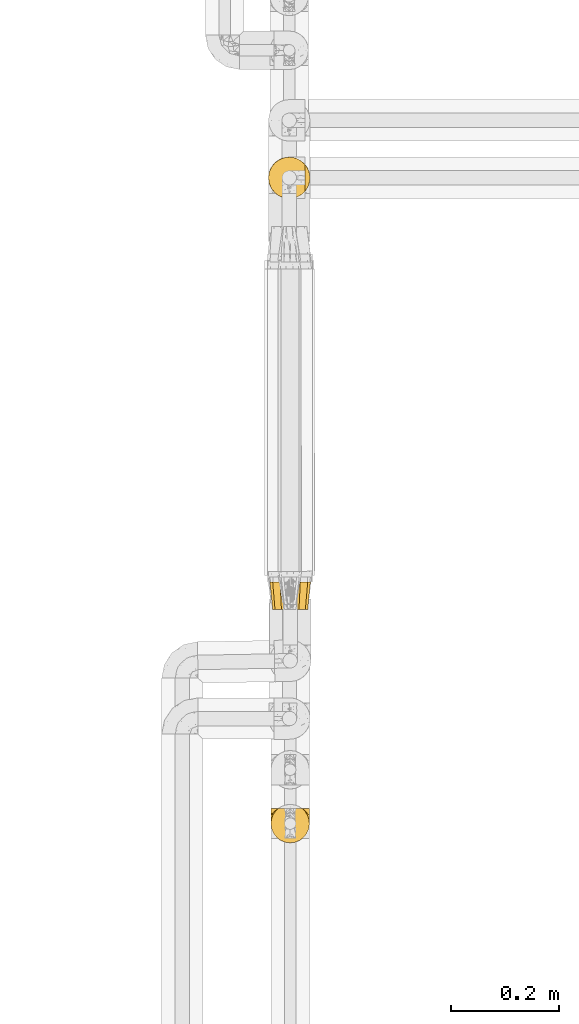
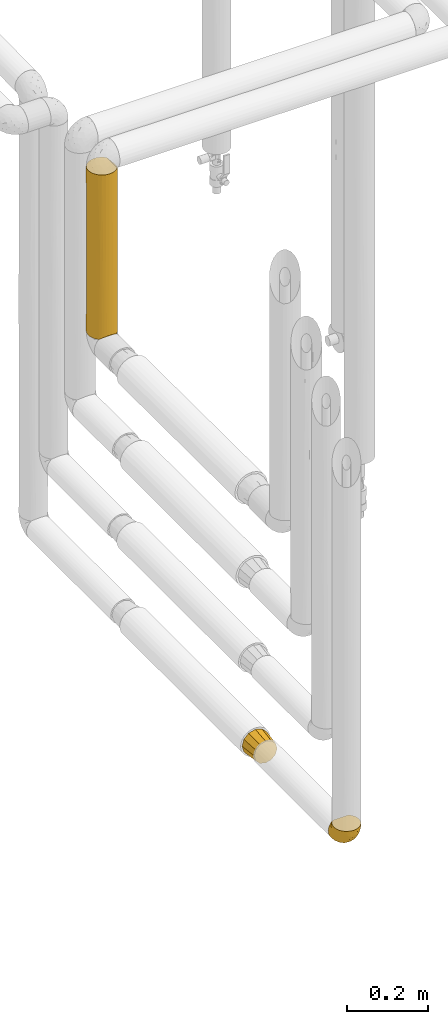
# One storey, part 75 of 827: 3 coverings.
"""IFC2X3 building model written with IfcOpenShell, lengths in millimetres."""

from ifc_helpers import new_model, entity, si_unit, converted_unit, derived_unit, direction, frame, origin, place, context, subcontext, project, spatial, faceted_brep, element, save


model = new_model("IFC2X3")

# Units and contexts
model_context = context("Model", 3, precision=0.01, world=origin(), true_north=direction((6.12303176911189e-17, 1.0)))
body_context = subcontext(model_context, "Body", "Model", "MODEL_VIEW")
ifc_project = project(units=[si_unit("LENGTHUNIT", "METRE", prefix="MILLI"), si_unit("AREAUNIT", "SQUARE_METRE"), si_unit("VOLUMEUNIT", "CUBIC_METRE"), converted_unit("PLANEANGLEUNIT", "DEGREE", entity("IfcRatioMeasure", 0.0174532925199433), si_unit("PLANEANGLEUNIT", "RADIAN"), dimensions=[0, 0, 0, 0, 0, 0, 0]), si_unit("MASSUNIT", "GRAM", prefix="KILO"), derived_unit("MASSDENSITYUNIT", [(si_unit("MASSUNIT", "GRAM", prefix="KILO"), 1), (si_unit("LENGTHUNIT", "METRE"), -3)]), derived_unit("MOMENTOFINERTIAUNIT", [(si_unit("LENGTHUNIT", "METRE"), 4)]), si_unit("TIMEUNIT", "SECOND"), si_unit("FREQUENCYUNIT", "HERTZ"), si_unit("THERMODYNAMICTEMPERATUREUNIT", "DEGREE_CELSIUS"), derived_unit("THERMALTRANSMITTANCEUNIT", [(si_unit("MASSUNIT", "GRAM", prefix="KILO"), 1), (si_unit("THERMODYNAMICTEMPERATUREUNIT", "KELVIN"), -1), (si_unit("TIMEUNIT", "SECOND"), -3)]), derived_unit("VOLUMETRICFLOWRATEUNIT", [(si_unit("LENGTHUNIT", "METRE"), 3), (si_unit("TIMEUNIT", "SECOND"), -1)]), derived_unit("MASSFLOWRATEUNIT", [(si_unit("MASSUNIT", "GRAM", prefix="KILO"), 1), (si_unit("TIMEUNIT", "SECOND"), -1)]), derived_unit("ROTATIONALFREQUENCYUNIT", [(si_unit("TIMEUNIT", "SECOND"), -1)]), si_unit("ELECTRICCURRENTUNIT", "AMPERE"), si_unit("ELECTRICVOLTAGEUNIT", "VOLT"), si_unit("POWERUNIT", "WATT"), si_unit("FORCEUNIT", "NEWTON", prefix="KILO"), si_unit("ILLUMINANCEUNIT", "LUX"), si_unit("LUMINOUSFLUXUNIT", "LUMEN"), si_unit("LUMINOUSINTENSITYUNIT", "CANDELA"), derived_unit("USERDEFINED", [(si_unit("MASSUNIT", "GRAM", prefix="KILO"), -1), (si_unit("LENGTHUNIT", "METRE"), -2), (si_unit("TIMEUNIT", "SECOND"), 3), (si_unit("LUMINOUSFLUXUNIT", "LUMEN"), 1)]), derived_unit("LINEARVELOCITYUNIT", [(si_unit("LENGTHUNIT", "METRE"), 1), (si_unit("TIMEUNIT", "SECOND"), -1)]), si_unit("PRESSUREUNIT", "PASCAL"), derived_unit("USERDEFINED", [(si_unit("LENGTHUNIT", "METRE"), -2), (si_unit("MASSUNIT", "GRAM", prefix="KILO"), 1), (si_unit("TIMEUNIT", "SECOND"), -2)]), derived_unit("LINEARFORCEUNIT", [(si_unit("MASSUNIT", "GRAM", prefix="KILO"), 1), (si_unit("LENGTHUNIT", "METRE"), 1), (si_unit("TIMEUNIT", "SECOND"), -2), (si_unit("LENGTHUNIT", "METRE"), -1)]), derived_unit("PLANARFORCEUNIT", [(si_unit("MASSUNIT", "GRAM", prefix="KILO"), 1), (si_unit("LENGTHUNIT", "METRE"), 1), (si_unit("TIMEUNIT", "SECOND"), -2), (si_unit("LENGTHUNIT", "METRE"), -2)])], contexts=[model_context])

# Site, building, storey
site_placement = place(None, origin())
site = spatial("IfcSite", under=ifc_project, at=site_placement, CompositionType="ELEMENT")
building_placement = place(site_placement, origin())
building = spatial("IfcBuilding", under=site, at=building_placement, CompositionType="ELEMENT")
storey_placement = place(building_placement, frame((0.0, 0.0, 28200.0)))
storey = spatial("IfcBuildingStorey", under=building, at=storey_placement, Name="08", CompositionType="ELEMENT", Elevation=28200.0)

# Coverings
covering_1_placement = place(storey_placement, frame((17886.73, 11719.52, 1375.75)))
element("IfcCovering", 1, at=covering_1_placement, inside=storey, Name=":ADSK_", ObjectType=":ADSK_", PredefinedType="INSULATION", context=body_context, shape_type="Brep", body=[
    faceted_brep([(63.08, 9.31, 495.15), (69.1, 14.94, 495.15), (69.1, 65.05, 495.15), (63.08, 70.68, 495.15), (56.01, 74.9, 495.15), (48.2, 77.51, 495.15), (40.0, 78.4, 495.15), (30.06, 77.09, 495.15), (20.8, 73.25, 495.15), (12.84, 67.15, 495.15), (6.74, 59.2, 495.15), (2.9, 49.93, 495.15), (1.6, 40.0, 495.15), (2.9, 30.06, 495.15), (6.74, 20.8, 495.15), (12.84, 12.84, 495.15), (20.8, 6.74, 495.15), (30.06, 2.9, 495.15), (40.0, 1.6, 495.15), (48.2, 2.48, 495.15), (56.01, 5.09, 495.15), (78.4, 40.0, 1.6), (77.51, 31.78, 1.6), (74.89, 23.96, 1.6), (70.66, 16.88, 1.6), (65.02, 10.87, 1.6), (14.91, 10.92, 1.6), (9.29, 16.93, 1.6), (5.08, 24.0, 1.6), (2.48, 31.8, 1.6), (1.6, 40.0, 1.6), (2.9, 49.93, 1.6), (6.74, 59.2, 1.6), (12.84, 67.15, 1.6), (20.8, 73.25, 1.6), (30.06, 77.09, 1.6), (40.0, 78.4, 1.6), (49.93, 77.09, 1.6), (59.2, 73.25, 1.6), (67.15, 67.15, 1.6), (73.25, 59.2, 1.6), (77.09, 49.93, 1.6), (50.17, 2.97, 245.86), (62.47, 8.86, 240.02), (59.48, 6.91, 5.56), (53.34, 3.99, 8.49), (56.56, 5.35, 187.37), (40.0, 1.6, 227.27), (46.77, 2.2, 10.28), (40.0, 1.6, 10.9), (77.02, 29.81, 250.89), (77.79, 33.21, 486.45), (76.0, 26.63, 488.25), (78.4, 40.0, 269.48), (71.11, 17.49, 256.76), (74.63, 23.41, 309.18), (78.4, 40.0, 485.85), (73.07, 20.48, 491.18), (77.02, 50.18, 254.37), (71.1, 62.51, 244.05), (74.64, 56.56, 189.86), (63.37, 70.46, 227.23), (77.79, 46.78, 486.45), (76.0, 53.36, 488.25), (73.07, 59.51, 491.18), (52.17, 76.41, 258.09), (40.0, 78.4, 278.78), (32.45, 77.65, 287.73), (25.3, 75.47, 248.37), (2.31, 47.36, 284.62), (4.52, 54.69, 248.37), (16.62, 70.46, 248.37), (9.53, 63.37, 248.37), (1.6, 40.0, 217.97), (3.57, 27.83, 238.63), (9.53, 16.62, 269.5), (29.79, 2.98, 242.35), (33.2, 2.2, 10.3), (23.4, 5.36, 306.39), (17.45, 8.91, 252.92), (26.61, 4.0, 8.5), (20.45, 6.94, 5.57)], [[[0, 1, 2, 3, 4, 5, 6, 7, 8, 9, 10, 11, 12, 13, 14, 15, 16, 17, 18, 19, 20]], [[21, 22, 23, 24, 25, 26, 27, 28, 29, 30, 31, 32, 33, 34, 35, 36, 37, 38, 39, 40, 41]], [[42, 20, 19]], [[20, 43, 0]], [[44, 25, 43]], [[42, 45, 46]], [[18, 47, 19]], [[43, 46, 44]], [[47, 42, 19]], [[47, 48, 42]], [[49, 48, 47]], [[50, 51, 52]], [[53, 50, 22]], [[43, 54, 1]], [[46, 20, 42]], [[50, 52, 55]], [[1, 0, 43]], [[55, 23, 50]], [[25, 24, 54]], [[23, 55, 54]], [[53, 56, 51]], [[23, 54, 24]], [[57, 1, 54]], [[42, 48, 45]], [[50, 23, 22]], [[53, 51, 50]], [[21, 53, 22]], [[55, 57, 54]], [[20, 46, 43]], [[57, 55, 52]], [[25, 54, 43]], [[44, 46, 45]], [[21, 58, 53]], [[58, 21, 41]], [[40, 59, 60]], [[59, 39, 61]], [[62, 58, 63]], [[62, 56, 53]], [[60, 63, 58]], [[64, 63, 60]], [[40, 39, 59]], [[59, 2, 64]], [[53, 58, 62]], [[61, 39, 38]], [[41, 60, 58]], [[38, 37, 65]], [[61, 3, 2]], [[64, 60, 59]], [[66, 6, 5]], [[65, 5, 4]], [[4, 61, 65]], [[66, 65, 37]], [[4, 3, 61]], [[66, 5, 65]], [[36, 66, 37]], [[65, 61, 38]], [[2, 59, 61]], [[41, 40, 60]], [[67, 35, 68]], [[31, 69, 70]], [[67, 6, 66, 36]], [[68, 35, 34]], [[67, 36, 35]], [[7, 68, 8]], [[68, 7, 67]], [[71, 9, 8]], [[71, 68, 34]], [[72, 71, 33]], [[12, 69, 73]], [[70, 32, 31]], [[31, 30, 73]], [[69, 11, 70]], [[12, 11, 69]], [[72, 10, 9]], [[70, 72, 32]], [[31, 73, 69]], [[70, 10, 72]], [[71, 72, 9]], [[33, 71, 34]], [[10, 70, 11]], [[32, 72, 33]], [[6, 67, 7]], [[68, 71, 8]], [[73, 29, 74]], [[28, 27, 75]], [[75, 74, 28]], [[47, 76, 77]], [[29, 73, 30]], [[74, 29, 28]], [[74, 14, 13]], [[75, 15, 14]], [[17, 16, 78]], [[79, 75, 26]], [[78, 80, 76]], [[79, 15, 75]], [[77, 76, 80]], [[16, 15, 79]], [[77, 49, 47]], [[78, 81, 80]], [[73, 74, 13]], [[78, 16, 79]], [[75, 27, 26]], [[18, 17, 76]], [[76, 47, 18]], [[74, 75, 14]], [[81, 78, 79]], [[81, 79, 26]], [[17, 78, 76]], [[12, 73, 13]], [[1, 57, 52, 51, 56, 62, 63, 64, 2]], [[45, 48, 49, 77, 80, 81, 26, 25, 44]]]),
])
covering_2_placement = place(storey_placement, frame((17891.28, 10523.96, 562.11)))
element("IfcCovering", 2, at=covering_2_placement, inside=storey, Name=":ADSK_", ObjectType=":ADSK_", PredefinedType="INSULATION", context=body_context, shape_type="Brep", body=[
    faceted_brep([(69.36, 65.25, 21.77), (65.11, 65.25, 15.01), (59.47, 65.25, 9.37), (52.71, 65.25, 5.12), (45.17, 65.25, 2.49), (37.25, 65.25, 1.6), (29.31, 65.25, 2.49), (21.77, 65.25, 5.13), (15.01, 65.25, 9.38), (9.37, 65.25, 15.02), (5.12, 65.25, 21.78), (2.49, 65.25, 29.32), (1.6, 65.25, 37.25), (2.48, 65.25, 45.15), (5.1, 65.25, 52.65), (9.31, 65.25, 59.39), (14.9, 65.25, 65.02), (16.96, 65.25, 65.02), (18.43, 65.25, 65.02), (20.19, 65.25, 65.02), (21.96, 65.25, 65.02), (23.72, 65.25, 65.02), (25.49, 65.25, 65.02), (27.25, 65.25, 65.02), (29.02, 65.25, 65.02), (30.78, 65.25, 65.02), (32.55, 65.25, 65.02), (34.31, 65.25, 65.02), (36.08, 65.25, 65.02), (37.84, 65.25, 65.02), (39.61, 65.25, 65.02), (41.37, 65.25, 65.02), (43.14, 65.25, 65.02), (45.19, 65.25, 65.02), (47.25, 65.25, 65.02), (49.31, 65.25, 65.02), (51.36, 65.25, 65.02), (53.42, 65.25, 65.02), (55.48, 65.25, 65.02), (57.53, 65.25, 65.02), (59.59, 65.25, 65.02), (65.19, 65.25, 59.38), (69.4, 65.25, 52.64), (72.01, 65.25, 45.13), (72.9, 65.25, 37.25), (72.0, 65.25, 29.31), (14.9, 65.02, 65.25), (9.3, 59.38, 65.25), (5.09, 52.65, 65.25), (2.48, 45.14, 65.25), (1.6, 37.25, 65.25), (2.81, 28.02, 65.25), (6.37, 19.42, 65.25), (12.04, 12.04, 65.25), (19.42, 6.37, 65.25), (28.02, 2.81, 65.25), (37.25, 1.6, 65.25), (46.47, 2.81, 65.25), (55.07, 6.37, 65.25), (62.45, 12.04, 65.25), (68.12, 19.42, 65.25), (71.68, 28.02, 65.25), (72.9, 37.25, 65.25), (72.01, 45.14, 65.25), (69.4, 52.65, 65.25), (65.19, 59.38, 65.25), (59.59, 65.02, 65.25), (58.56, 65.02, 65.25), (56.8, 65.02, 65.25), (55.4, 65.02, 65.25), (54.0, 65.02, 65.25), (52.61, 65.02, 65.25), (51.21, 65.02, 65.25), (49.81, 65.02, 65.25), (48.42, 65.02, 65.25), (47.02, 65.02, 65.25), (45.62, 65.02, 65.25), (44.23, 65.02, 65.25), (42.83, 65.02, 65.25), (41.43, 65.02, 65.25), (40.04, 65.02, 65.25), (38.64, 65.02, 65.25), (37.25, 65.02, 65.25), (35.48, 65.02, 65.25), (33.72, 65.02, 65.25), (31.95, 65.02, 65.25), (30.19, 65.02, 65.25), (28.42, 65.02, 65.25), (26.66, 65.02, 65.25), (24.89, 65.02, 65.25), (23.13, 65.02, 65.25), (21.07, 65.02, 65.25), (19.01, 65.02, 65.25), (16.96, 65.02, 65.25), (50.36, 65.09, 65.08), (51.91, 65.08, 65.09), (27.73, 65.08, 65.09), (29.06, 65.08, 65.1), (23.0, 65.1, 65.08), (39.29, 65.08, 65.09), (16.3, 65.09, 65.09), (17.69, 65.09, 65.09), (42.09, 65.09, 65.09), (43.53, 65.08, 65.1), (58.23, 65.1, 65.08), (59.59, 65.09, 65.09), (46.32, 65.1, 65.08), (47.68, 65.08, 65.09), (19.0, 65.09, 65.08), (30.39, 65.09, 65.09), (31.67, 65.1, 65.07), (37.94, 65.08, 65.1), (36.57, 65.08, 65.09), (45.01, 65.08, 65.1), (35.19, 65.11, 65.07), (26.37, 65.1, 65.07), (25.1, 65.09, 65.09), (56.91, 65.1, 65.08), (40.68, 65.09, 65.09), (32.77, 65.06, 65.13), (20.34, 65.08, 65.1), (21.67, 65.08, 65.09), (33.92, 65.09, 65.09), (53.39, 65.08, 65.1), (54.7, 65.09, 65.09), (14.9, 65.09, 65.09), (49.03, 65.08, 65.09), (3.58, 53.73, 53.74), (6.24, 58.66, 57.19), (1.6, 41.0, 51.25), (1.6, 38.71, 59.77), (1.6, 51.25, 41.0), (9.92, 61.64, 61.64), (1.6, 46.12, 46.12), (1.6, 59.77, 38.71), (27.59, 31.28, 13.0), (25.47, 49.86, 5.55), (37.25, 40.89, 6.44), (2.33, 31.44, 55.39), (2.37, 34.1, 48.48), (8.53, 23.33, 39.63), (15.54, 13.33, 43.5), (8.96, 17.24, 52.38), (4.31, 26.77, 49.31), (4.31, 24.24, 58.01), (7.06, 46.39, 22.23), (7.06, 56.32, 19.14), (12.03, 51.97, 13.73), (2.3, 41.92, 39.1), (21.13, 32.23, 15.38), (30.63, 5.01, 46.7), (23.6, 6.41, 49.4), (37.25, 52.55, 4.12), (15.54, 9.84, 55.35), (18.65, 24.05, 23.83), (15.3, 33.5, 19.0), (3.14, 45.31, 32.44), (3.59, 55.32, 26.73), (18.27, 54.18, 8.12), (7.07, 32.73, 31.34), (3.86, 34.55, 38.81), (13.04, 42.44, 16.11), (18.27, 41.89, 11.96), (26.27, 22.65, 20.31), (23.06, 10.6, 38.81), (29.25, 10.01, 35.48), (24.41, 15.9, 28.94), (31.04, 16.46, 25.21), (37.25, 20.24, 20.24), (37.25, 30.56, 13.34), (37.25, 4.12, 52.55), (15.08, 19.45, 33.16), (12.03, 27.92, 27.33), (9.82, 37.29, 22.86), (6.14, 40.02, 27.48), (37.25, 6.44, 40.89), (37.25, 13.34, 30.56), (70.18, 25.04, 54.41), (44.04, 5.04, 46.71), (49.17, 17.52, 26.31), (46.9, 31.3, 12.98), (62.45, 51.97, 13.72), (56.21, 54.19, 8.12), (65.53, 19.41, 46.04), (58.95, 10.78, 51.06), (58.17, 16.67, 35.69), (67.43, 46.4, 22.22), (67.43, 56.32, 19.13), (70.89, 55.32, 26.72), (55.13, 28.05, 19.65), (72.21, 32.97, 51.87), (72.9, 41.0, 51.25), (72.9, 39.12, 58.25), (72.9, 59.77, 38.71), (49.42, 4.71, 54.36), (65.53, 16.32, 56.5), (45.41, 10.37, 34.9), (50.89, 8.45, 43.16), (49.01, 49.86, 5.54), (66.8, 27.54, 35.66), (70.39, 28.28, 47.21), (56.21, 41.9, 11.95), (72.31, 36.5, 46.27), (72.1, 40.35, 39.95), (72.9, 51.25, 41.0), (72.9, 46.12, 46.12), (62.45, 40.24, 18.27), (71.35, 45.3, 32.43), (72.26, 31.14, 58.69), (62.45, 27.93, 27.31), (67.99, 36.19, 29.52), (62.85, 21.94, 35.02), (70.57, 32.75, 40.81), (70.91, 53.73, 53.74), (68.25, 57.19, 58.66), (64.57, 61.64, 61.64)], [[[0, 1, 2, 3, 4, 5, 6, 7, 8, 9, 10, 11, 12, 13, 14, 15, 16, 17, 18, 19, 20, 21, 22, 23, 24, 25, 26, 27, 28, 29, 30, 31, 32, 33, 34, 35, 36, 37, 38, 39, 40, 41, 42, 43, 44, 45]], [[46, 47, 48, 49, 50, 51, 52, 53, 54, 55, 56, 57, 58, 59, 60, 61, 62, 63, 64, 65, 66, 67, 68, 69, 70, 71, 72, 73, 74, 75, 76, 77, 78, 79, 80, 81, 82, 83, 84, 85, 86, 87, 88, 89, 90, 91, 92, 93]], [[94, 72, 95]], [[96, 87, 97]], [[20, 98, 21]], [[99, 81, 80]], [[100, 93, 101]], [[102, 103, 32]], [[104, 105, 40]], [[67, 105, 104]], [[106, 107, 34]], [[18, 101, 108]], [[109, 85, 110]], [[36, 94, 95]], [[81, 111, 82]], [[29, 28, 112]], [[17, 101, 18]], [[103, 113, 33]], [[24, 96, 97]], [[28, 114, 112]], [[115, 22, 116]], [[31, 102, 32]], [[68, 104, 117]], [[31, 118, 102]], [[84, 119, 85]], [[120, 91, 121]], [[23, 22, 115]], [[114, 27, 122]], [[123, 37, 95]], [[117, 124, 69]], [[67, 66, 105]], [[104, 39, 117]], [[123, 124, 37]], [[100, 17, 16]], [[100, 125, 46]], [[17, 100, 101]], [[107, 126, 35]], [[92, 108, 101]], [[115, 88, 96]], [[114, 122, 83]], [[101, 93, 92]], [[93, 100, 46]], [[16, 125, 100]], [[108, 19, 18]], [[120, 121, 19]], [[108, 92, 120]], [[19, 108, 120]], [[67, 104, 68]], [[39, 104, 40]], [[69, 68, 117]], [[117, 39, 38]], [[70, 124, 123]], [[124, 70, 69]], [[38, 124, 117]], [[124, 38, 37]], [[72, 71, 95]], [[71, 123, 95]], [[71, 70, 123]], [[126, 94, 35]], [[37, 36, 95]], [[75, 74, 107]], [[73, 72, 94]], [[94, 36, 35]], [[94, 126, 73]], [[74, 73, 126]], [[106, 76, 75]], [[76, 106, 113]], [[113, 106, 33]], [[107, 35, 34]], [[106, 34, 33]], [[126, 107, 74]], [[107, 106, 75]], [[78, 77, 103]], [[77, 113, 103]], [[77, 76, 113]], [[102, 78, 103]], [[33, 32, 103]], [[80, 79, 118]], [[102, 118, 79]], [[112, 111, 29]], [[118, 31, 30]], [[79, 78, 102]], [[99, 111, 81]], [[112, 82, 111]], [[111, 99, 29]], [[30, 29, 99]], [[112, 83, 82]], [[27, 114, 28]], [[99, 118, 30]], [[118, 99, 80]], [[114, 83, 112]], [[84, 83, 122]], [[109, 110, 25]], [[122, 27, 26]], [[119, 110, 85]], [[20, 19, 121]], [[25, 110, 26]], [[91, 120, 92]], [[90, 98, 121]], [[121, 91, 90]], [[23, 115, 96]], [[88, 115, 116]], [[116, 98, 89]], [[89, 88, 116]], [[23, 96, 24]], [[87, 96, 88]], [[25, 24, 109]], [[97, 87, 86]], [[90, 89, 98]], [[116, 22, 21]], [[122, 26, 119]], [[86, 85, 109]], [[109, 97, 86]], [[97, 109, 24]], [[110, 119, 26]], [[122, 119, 84]], [[121, 98, 20]], [[21, 98, 116]], [[48, 127, 49]], [[48, 47, 128]], [[49, 129, 130, 50]], [[129, 49, 127]], [[131, 127, 13]], [[46, 125, 132]], [[16, 15, 132]], [[127, 128, 14]], [[127, 131, 133, 129]], [[14, 13, 127]], [[13, 12, 134, 131]], [[46, 132, 47]], [[48, 128, 127]], [[47, 132, 128]], [[15, 128, 132]], [[125, 16, 132]], [[15, 14, 128]], [[135, 136, 137]], [[138, 129, 139]], [[140, 141, 142]], [[143, 144, 138]], [[145, 146, 147]], [[133, 148, 139]], [[134, 12, 11]], [[136, 135, 149]], [[150, 55, 151]], [[136, 6, 152]], [[153, 54, 53]], [[52, 144, 142]], [[52, 142, 53]], [[54, 153, 151]], [[144, 52, 51]], [[154, 155, 149]], [[156, 131, 157]], [[134, 11, 157]], [[8, 7, 158]], [[147, 9, 8]], [[157, 131, 134]], [[157, 11, 10]], [[146, 157, 10]], [[159, 140, 160]], [[157, 145, 156]], [[161, 162, 155]], [[161, 147, 162]], [[154, 149, 163]], [[150, 164, 165]], [[136, 7, 6]], [[137, 136, 152]], [[162, 158, 136]], [[54, 151, 55]], [[158, 147, 8]], [[166, 167, 165]], [[9, 146, 10]], [[164, 166, 165]], [[168, 135, 137, 169]], [[55, 150, 170]], [[154, 171, 172]], [[139, 148, 160]], [[140, 142, 143]], [[153, 142, 141]], [[51, 50, 130]], [[145, 173, 174]], [[156, 160, 148]], [[6, 5, 152]], [[136, 158, 7]], [[147, 158, 162]], [[147, 146, 9]], [[157, 146, 145]], [[160, 140, 143]], [[140, 172, 171]], [[139, 143, 138]], [[173, 159, 174]], [[170, 150, 175]], [[170, 56, 55]], [[167, 168, 176]], [[176, 175, 165]], [[150, 165, 175]], [[163, 167, 166]], [[176, 165, 167]], [[164, 150, 151]], [[151, 141, 164]], [[171, 164, 141]], [[154, 163, 166]], [[163, 135, 168]], [[166, 164, 171]], [[155, 154, 172]], [[166, 171, 154]], [[140, 171, 141]], [[173, 155, 172]], [[149, 155, 162]], [[159, 173, 172]], [[161, 145, 147]], [[140, 159, 172]], [[174, 160, 156]], [[136, 149, 162]], [[149, 135, 163]], [[155, 173, 161]], [[145, 161, 173]], [[160, 174, 159]], [[156, 148, 131]], [[156, 145, 174]], [[142, 153, 53]], [[151, 153, 141]], [[138, 51, 130]], [[142, 144, 143]], [[51, 138, 144]], [[129, 138, 130]], [[133, 139, 129]], [[160, 143, 139]], [[168, 167, 163]], [[131, 148, 133]], [[60, 177, 61]], [[175, 178, 170]], [[179, 168, 180]], [[178, 57, 170]], [[181, 182, 2]], [[183, 184, 185]], [[186, 187, 188]], [[189, 185, 179]], [[190, 191, 192]], [[45, 193, 188]], [[194, 184, 58]], [[45, 44, 193]], [[59, 195, 60]], [[60, 195, 177]], [[0, 45, 188]], [[196, 179, 197]], [[180, 137, 198]], [[183, 199, 200]], [[201, 182, 181]], [[1, 181, 2]], [[57, 178, 194]], [[198, 3, 182]], [[198, 152, 4]], [[1, 0, 187]], [[190, 202, 191]], [[203, 204, 205]], [[206, 201, 181]], [[186, 188, 207]], [[188, 204, 207]], [[3, 198, 4]], [[58, 184, 59]], [[187, 181, 1]], [[180, 198, 201]], [[206, 181, 186]], [[180, 189, 179]], [[3, 2, 182]], [[180, 168, 169, 137]], [[204, 188, 193]], [[177, 190, 208]], [[209, 210, 199]], [[210, 186, 207]], [[185, 184, 197]], [[195, 184, 183]], [[205, 202, 203]], [[210, 209, 206]], [[179, 185, 197]], [[211, 209, 199]], [[196, 197, 178]], [[180, 201, 189]], [[152, 198, 137]], [[152, 5, 4]], [[61, 208, 62]], [[198, 182, 201]], [[188, 187, 0]], [[181, 187, 186]], [[203, 210, 207]], [[202, 205, 191]], [[199, 210, 212]], [[57, 56, 170]], [[176, 196, 175]], [[178, 197, 194]], [[179, 176, 168]], [[175, 196, 178]], [[176, 179, 196]], [[184, 194, 197]], [[58, 57, 194]], [[208, 190, 192]], [[200, 190, 177]], [[206, 189, 201]], [[185, 189, 209]], [[62, 208, 192]], [[177, 208, 61]], [[210, 206, 186]], [[189, 206, 209]], [[200, 199, 212]], [[211, 183, 185]], [[184, 195, 59]], [[177, 195, 183]], [[183, 200, 177]], [[202, 200, 212]], [[200, 202, 190]], [[202, 212, 203]], [[210, 203, 212]], [[204, 203, 207]], [[183, 211, 199]], [[185, 209, 211]], [[63, 62, 192, 191]], [[64, 63, 213]], [[64, 213, 214]], [[65, 215, 66]], [[213, 191, 205, 204]], [[43, 204, 193, 44]], [[65, 214, 215]], [[42, 213, 43]], [[215, 105, 66]], [[41, 214, 42]], [[40, 105, 215]], [[65, 64, 214]], [[40, 215, 41]], [[213, 63, 191]], [[42, 214, 213]], [[204, 43, 213]], [[214, 41, 215]]]),
])
covering_3_placement = place(storey_placement, frame((17889.43, 10958.2, 560.26)))
element("IfcCovering", 3, at=covering_3_placement, inside=storey, Name=":ADSK_", ObjectType=":ADSK_", PredefinedType="INSULATION", context=body_context, shape_type="Brep", body=[
    faceted_brep([(10.95, 0.0, 55.35), (8.77, 0.0, 47.22), (6.6, 0.0, 39.1), (8.77, 0.0, 30.97), (10.95, 0.0, 22.85), (16.9, 0.0, 16.9), (22.85, 0.0, 10.95), (30.97, 0.0, 8.77), (39.1, 0.0, 6.6), (47.22, 0.0, 8.77), (55.35, 0.0, 10.95), (61.29, 0.0, 16.9), (67.24, 0.0, 22.85), (69.42, 0.0, 30.97), (71.6, 0.0, 39.1), (69.42, 0.0, 47.22), (67.24, 0.0, 55.35), (61.29, 0.0, 61.29), (55.35, 0.0, 67.24), (47.22, 0.0, 69.42), (39.1, 0.0, 71.6), (30.97, 0.0, 69.42), (22.85, 0.0, 67.24), (16.9, 0.0, 61.29), (64.71, 51.0, 64.71), (71.57, 51.0, 57.85), (73.22, 51.0, 51.69), (74.91, 51.0, 45.39), (76.6, 51.0, 39.1), (74.91, 51.0, 32.8), (73.22, 51.0, 26.5), (71.57, 51.0, 20.35), (64.71, 51.0, 13.48), (57.85, 51.0, 6.62), (51.69, 51.0, 4.97), (45.39, 51.0, 3.28), (39.1, 51.0, 1.6), (32.8, 51.0, 3.28), (26.5, 51.0, 4.97), (20.35, 51.0, 6.62), (13.48, 51.0, 13.48), (6.62, 51.0, 20.35), (4.97, 51.0, 26.5), (3.28, 51.0, 32.8), (1.6, 51.0, 39.1), (3.28, 51.0, 45.39), (4.97, 51.0, 51.69), (6.62, 51.0, 57.85), (13.48, 51.0, 64.71), (20.35, 51.0, 71.57), (26.5, 51.0, 73.22), (32.8, 51.0, 74.91), (39.1, 51.0, 76.6), (45.39, 51.0, 74.91), (51.69, 51.0, 73.22), (57.85, 51.0, 71.57)], [[[0, 1, 2, 3, 4, 5, 6, 7, 8, 9, 10, 11, 12, 13, 14, 15, 16, 17, 18, 19, 20, 21, 22, 23]], [[24, 25, 26, 27, 28, 29, 30, 31, 32, 33, 34, 35, 36, 37, 38, 39, 40, 41, 42, 43, 44, 45, 46, 47, 48, 49, 50, 51, 52, 53, 54, 55]], [[6, 39, 38, 37, 36, 8, 7]], [[41, 40, 39, 6, 5, 4]], [[44, 43, 42, 41, 4, 3, 2]], [[12, 31, 30, 29, 28, 14, 13]], [[33, 32, 31, 12, 11, 10]], [[36, 35, 34, 33, 10, 9, 8]], [[18, 55, 54, 53, 52, 20, 19]], [[25, 24, 55, 18, 17, 16]], [[28, 27, 26, 25, 16, 15, 14]], [[0, 47, 46, 45, 44, 2, 1]], [[49, 48, 47, 0, 23, 22]], [[52, 51, 50, 49, 22, 21, 20]]]),
])

save(model, "model.ifc")
